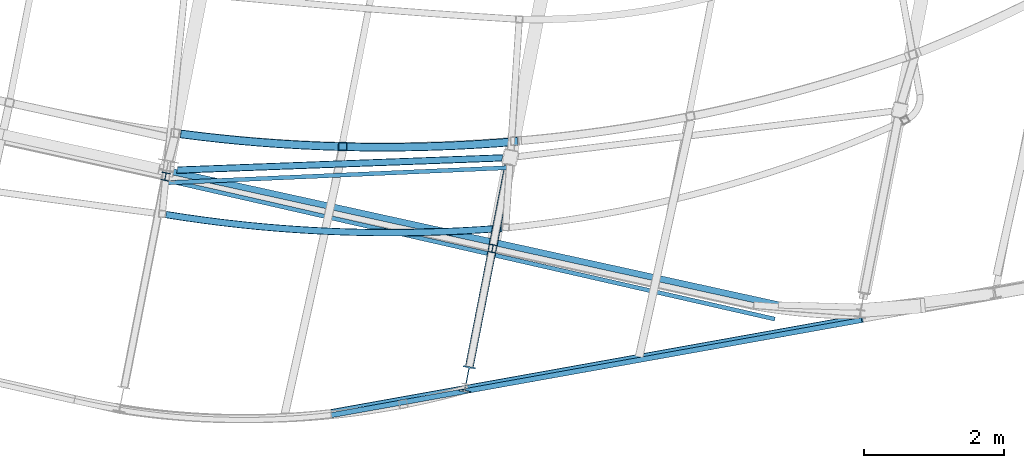
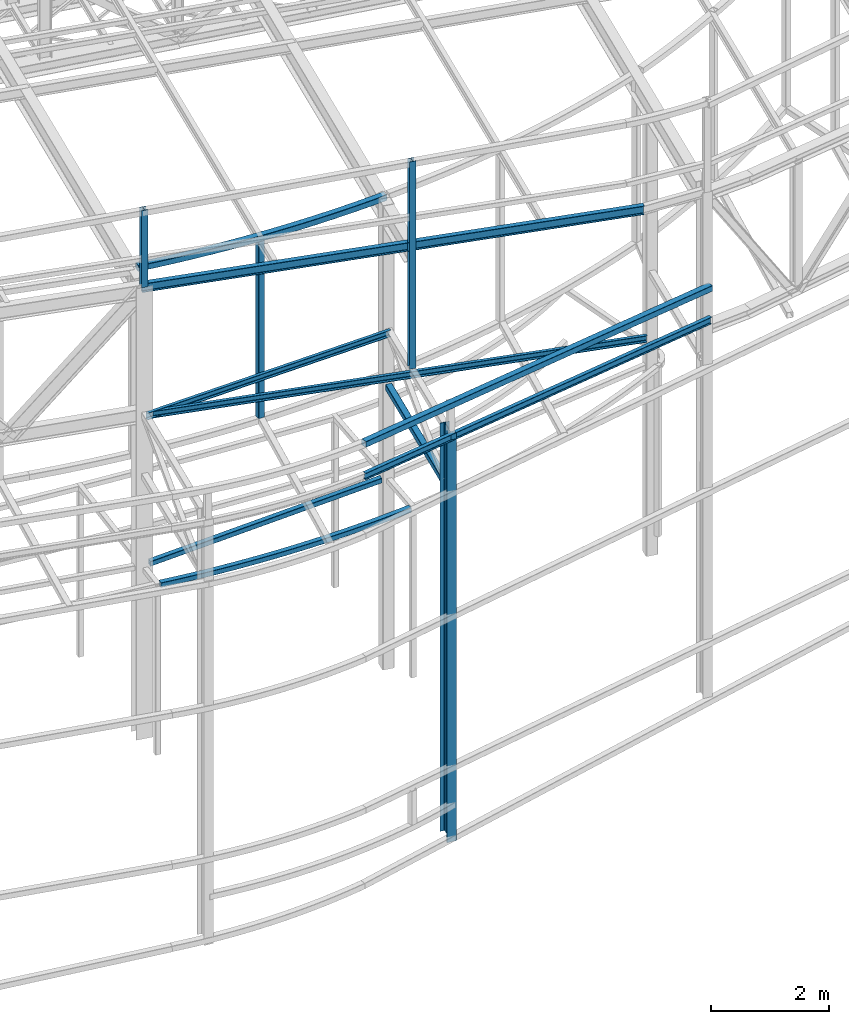
# One storey, part 51 of 215: 13 beams, 13 elements without a shape of their own.
"""IFC2X3 building model written with IfcOpenShell, lengths in millimetres."""

from ifc_helpers import new_model, entity, si_unit, frame, origin_with_axes, origin_2d_with_axis, place, context, subcontext, project, spatial, hollow_rectangle, i_section, u_section, extrude, clip, halfspace, material, type_object, element, aggregate, save


model = new_model("IFC2X3")

# Units and contexts
model_context = context("Model", 3, precision=1e-05, world=origin_with_axes())
body_context = subcontext(model_context, "Body", "Model", "MODEL_VIEW")
ifc_project = project(units=[si_unit("LENGTHUNIT", "METRE", prefix="MILLI"), si_unit("AREAUNIT", "SQUARE_METRE"), si_unit("VOLUMEUNIT", "CUBIC_METRE"), si_unit("MASSUNIT", "GRAM", prefix="KILO"), si_unit("TIMEUNIT", "SECOND"), si_unit("PLANEANGLEUNIT", "RADIAN"), si_unit("SOLIDANGLEUNIT", "STERADIAN"), si_unit("THERMODYNAMICTEMPERATUREUNIT", "DEGREE_CELSIUS"), si_unit("LUMINOUSINTENSITYUNIT", "LUMEN")], contexts=[model_context])

# Site, building, storey
site_placement = place(None, origin_with_axes())
site = spatial("IfcSite", under=ifc_project, at=site_placement, CompositionType="ELEMENT")
building_placement = place(site_placement, origin_with_axes())
building = spatial("IfcBuilding", under=site, at=building_placement, Name="Undefined", CompositionType="ELEMENT")
storey_placement = place(building_placement, origin_with_axes())
storey = spatial("IfcBuildingStorey", under=building, at=storey_placement, Name="Undefined", CompositionType="ELEMENT", Elevation=0.0)

# Assembly, beam
assembly_1_placement = place(storey_placement, origin_with_axes())
assembly_1 = element("IfcElementAssembly", 1, at=assembly_1_placement, inside=storey, Name="Steel Assembly", AssemblyPlace="NOTDEFINED", PredefinedType="RIGID_FRAME")
ifc_material = material(Name="STEEL/S275JR")
beam_type_1 = type_object("IfcBeamType", PredefinedType="NOTDEFINED")
beam_1_placement = place(assembly_1_placement, frame((74261.1152810842, 3775.93110748871, 6760.00000147687), z_axis=(-0.0375601719917873, 0.99929436778156, 0.0), x_axis=(0.99929436778156, 0.0375601719917896, 0.0)))
beam_1 = element("IfcBeam", 2, at=beam_1_placement, type_object=beam_type_1, material=ifc_material, Name="POUTRE", context=body_context, shape_type="Clipping", body=[
    clip(clip(extrude(hollow_rectangle(XDim=100.0, YDim=100.0, WallThickness=4.0, InnerFilletRadius=4.0, OuterFilletRadius=8.0, at=origin_2d_with_axis()), frame((4817.4486174556, 0.0, 0.0), z_axis=(-1.0, 0.0, 0.0), x_axis=(-6.93889390390723e-18, -1.0, -3.46944695195361e-18)), (0.0, 0.0, 1.0), 4692.2), halfspace(frame((4774.49299238823, -50.0, -81.9430866269604), z_axis=(0.973523614887649, 0.0, -0.228586463413922), x_axis=(-6.93889390390723e-18, -1.0, -3.46944695195361e-18)), False)), halfspace(frame((119.885956215003, -50.0, -123.641085699432), z_axis=(0.973523614887649, 0.0, -0.228586463413922), x_axis=(-6.93889390390723e-18, -1.0, -3.46944695195361e-18)), True)),
])
aggregate(assembly_1, [beam_1])

assembly_2_placement = place(storey_placement, origin_with_axes())
assembly_2 = element("IfcElementAssembly", 3, at=assembly_2_placement, inside=storey, Name="Steel Assembly", AssemblyPlace="NOTDEFINED", PredefinedType="RIGID_FRAME")
beam_2_placement = place(assembly_2_placement, frame((74250.9672434929, 3147.06143421459, 6760.00000147688), z_axis=(0.0406259980144075, 0.999174423354268, 0.0), x_axis=(0.999174423354268, -0.0406259980144044, 0.0)))
beam_2 = element("IfcBeam", 4, at=beam_2_placement, type_object=beam_type_1, material=ifc_material, Name="POUTRE", context=body_context, shape_type="SweptSolid", body=[
    entity("IfcRevolvedAreaSolid", entity("IfcRectangleHollowProfileDef", "AREA", None, entity("IfcAxis2Placement2D", entity("IfcCartesianPoint", [0.0, 0.0]), entity("IfcDirection", [1.0, 0.0])), 100.0, 100.0, 4.0, 4.0, 8.0), entity("IfcAxis2Placement3D", entity("IfcCartesianPoint", [4794.64242956755, 0.0, -9.42764216898869e-13]), entity("IfcDirection", [-0.99275375487674, 0.0, -0.120166476931518]), entity("IfcDirection", [-6.93889390390723e-18, -1.0, -3.46944695195361e-18])), entity("IfcAxis1Placement", entity("IfcCartesianPoint", [0.0, 19950.0, 0.0]), entity("IfcDirection", [-1.0, 0.0, 0.0])), 0.24091514552611),
])
aggregate(assembly_2, [beam_2])

assembly_3_placement = place(storey_placement, origin_with_axes())
assembly_3 = element("IfcElementAssembly", 5, at=assembly_3_placement, inside=storey, Name="Steel Assembly", AssemblyPlace="NOTDEFINED", PredefinedType="RIGID_FRAME")
beam_type_2 = type_object("IfcBeamType", PredefinedType="NOTDEFINED")
beam_3_placement = place(assembly_3_placement, frame((84192.2325806334, 1667.38669545206, 10334.7722522313), z_axis=(0.030333910010468, 0.00543797900187643, 0.999525028344889), x_axis=(-0.98384073926679, -0.176373700047828, 0.0308174900083568)))
beam_3 = element("IfcBeam", 6, at=beam_3_placement, type_object=beam_type_2, material=ifc_material, Name="LISSE", context=body_context, shape_type="SweptSolid", body=[
    extrude(hollow_rectangle(XDim=120.0, YDim=120.0, WallThickness=4.0, InnerFilletRadius=4.0, OuterFilletRadius=8.0, at=origin_2d_with_axis()), frame((7707.6528923593, -1.22814174666988e-13, -2.67412928341124e-14), z_axis=(-1.0, 0.0, 0.0), x_axis=(-6.93889390390723e-18, -1.0, -3.46944695195361e-18)), (0.0, 0.0, 1.0), 7707.7),
])
aggregate(assembly_3, [beam_3])

assembly_4_placement = place(storey_placement, origin_with_axes())
assembly_4 = element("IfcElementAssembly", 7, at=assembly_4_placement, inside=storey, Name="Steel Assembly", AssemblyPlace="NOTDEFINED", PredefinedType="RIGID_FRAME")
beam_type_3 = type_object("IfcBeamType", PredefinedType="NOTDEFINED")
beam_4_placement = place(assembly_4_placement, frame((76773.3596225124, 4118.8705925803, 12545.1918488678), z_axis=(-0.00211529999947707, -0.999997762750453, 0.0), x_axis=(0.0, 0.0, -1.0)))
beam_4 = element("IfcBeam", 8, at=beam_4_placement, type_object=beam_type_3, material=ifc_material, Name="LISSE", context=body_context, shape_type="SweptSolid", body=[
    extrude(hollow_rectangle(XDim=120.0, YDim=120.0, WallThickness=5.0, InnerFilletRadius=5.0, OuterFilletRadius=10.0, at=origin_2d_with_axis()), frame((3779.1910443004, -1.45519152533754e-11, 0.0), z_axis=(-1.0, 0.0, 0.0), x_axis=(-6.93889390390723e-18, -1.0, -3.46944695195361e-18)), (0.0, 0.0, 1.0), 3779.2),
])
aggregate(assembly_4, [beam_4])

assembly_5_placement = place(storey_placement, origin_with_axes())
assembly_5 = element("IfcElementAssembly", 9, at=assembly_5_placement, inside=storey, Name="Steel Assembly", AssemblyPlace="NOTDEFINED", PredefinedType="RIGID_FRAME")
beam_5_placement = place(assembly_5_placement, frame((79267.1867346252, 4191.7690236405, 12410.541358688), z_axis=(-0.0310311480063228, 0.000686511000139884, -0.999518182203834), x_axis=(-0.999273695664124, 0.0221060559925697, 0.0310387409895674)))
beam_5 = element("IfcBeam", 10, at=beam_5_placement, type_object=beam_type_3, material=ifc_material, Name="LISSE", context=body_context, shape_type="SweptSolid", body=[
    entity("IfcRevolvedAreaSolid", entity("IfcRectangleHollowProfileDef", "AREA", None, entity("IfcAxis2Placement2D", entity("IfcCartesianPoint", [0.0, 0.0]), entity("IfcDirection", [1.0, 0.0])), 120.0, 120.0, 5.0, 5.0, 10.0), entity("IfcAxis2Placement3D", entity("IfcCartesianPoint", [4808.92307548659, -9.31427089451216e-13, 1.66843035064264e-14]), entity("IfcDirection", [-0.994042139631075, -0.108996443234057, -3.43653205685092e-18]), entity("IfcDirection", [0.108996443234057, -0.994042139631075, 4.89825829785122e-19])), entity("IfcAxis1Placement", entity("IfcCartesianPoint", [-22060.0, 0.0, 0.0]), entity("IfcDirection", [-6.93889390390723e-18, -1.0, -3.46944695195361e-18])), 0.218426844555447),
])
aggregate(assembly_5, [beam_5])

assembly_6_placement = place(storey_placement, origin_with_axes())
assembly_6 = element("IfcElementAssembly", 11, at=assembly_6_placement, inside=storey, Name="Steel Assembly", AssemblyPlace="NOTDEFINED", PredefinedType="RIGID_FRAME")
beam_6_placement = place(assembly_6_placement, frame((79143.2731267829, 3852.2721506294, 8710.00002272178), z_axis=(0.0, 0.0, 1.0), x_axis=(-0.191859508000518, -0.981422401002646, -1.00000033853845e-09)))
beam_6 = element("IfcBeam", 12, at=beam_6_placement, type_object=beam_type_3, material=ifc_material, Name="POUTRE", context=body_context, shape_type="SweptSolid", body=[
    extrude(hollow_rectangle(XDim=120.0, YDim=120.0, WallThickness=5.0, InnerFilletRadius=5.0, OuterFilletRadius=10.0, at=origin_2d_with_axis()), frame((2932.26845998588, 5.62583432590047e-16, -6.06378905225262e-22), z_axis=(-1.0, 0.0, 0.0), x_axis=(-6.93889390390723e-18, -1.0, -3.46944695195361e-18)), (0.0, 0.0, 1.0), 2932.3),
])
aggregate(assembly_6, [beam_6])

assembly_7_placement = place(storey_placement, origin_with_axes())
assembly_7 = element("IfcElementAssembly", 13, at=assembly_7_placement, inside=storey, Name="Steel Assembly", AssemblyPlace="NOTDEFINED", PredefinedType="RIGID_FRAME")
beam_type_4 = type_object("IfcBeamType", Name="UPN140", PredefinedType="NOTDEFINED")
beam_7_placement = place(assembly_7_placement, frame((82939.485591898, 1655.68782087957, 9717.96646806902), z_axis=(-0.0268944750036359, 0.00613499200083085, -0.999619452135376), x_axis=(-0.974584372423982, 0.222315879096716, 0.0275853390120007)))
beam_7 = element("IfcBeam", 14, at=beam_7_placement, type_object=beam_type_4, material=ifc_material, ObjectType="UPN140", context=body_context, shape_type="SweptSolid", body=[
    extrude(u_section(Depth=140.0, FlangeWidth=60.0, WebThickness=7.0, FlangeThickness=10.0, FilletRadius=10.0, EdgeRadius=5.0, FlangeSlope=0.0798299857122373, at=origin_2d_with_axis()), frame((8783.7502311137, 3.44692992864887e-12, 3.04747554660593e-14), z_axis=(-1.0, 0.0, 0.0), x_axis=(-6.93889390390723e-18, -1.0, -3.46944695195361e-18)), (0.0, 0.0, 1.0), 8783.8),
])
aggregate(assembly_7, [beam_7])

assembly_8_placement = place(storey_placement, origin_with_axes())
assembly_8 = element("IfcElementAssembly", 15, at=assembly_8_placement, inside=storey, Name="Steel Assembly", AssemblyPlace="NOTDEFINED", PredefinedType="RIGID_FRAME")
beam_8_placement = place(assembly_8_placement, frame((79149.5642694541, 3816.73288514796, 9850.00376637178), z_axis=(-0.0238106859918893, -0.00105414299964089, -0.999715929659587), x_axis=(-0.998737583884963, -0.044217400994907, 0.0238340089972549)))
beam_8 = element("IfcBeam", 16, at=beam_8_placement, type_object=beam_type_4, material=ifc_material, ObjectType="UPN140", context=body_context, shape_type="SweptSolid", body=[
    extrude(u_section(Depth=140.0, FlangeWidth=60.0, WebThickness=7.0, FlangeThickness=10.0, FilletRadius=10.0, EdgeRadius=5.0, FlangeSlope=0.0798299857122373, at=origin_2d_with_axis()), frame((4901.31854594592, -2.88501916874359e-13, 3.62097394240193e-12), z_axis=(-1.0, 0.0, 0.0), x_axis=(-6.93889390390723e-18, -1.0, -3.46944695195361e-18)), (0.0, 0.0, 1.0), 4901.3),
])
aggregate(assembly_8, [beam_8])

assembly_9_placement = place(storey_placement, origin_with_axes())
assembly_9 = element("IfcElementAssembly", 17, at=assembly_9_placement, inside=storey, Name="Steel Assembly", AssemblyPlace="NOTDEFINED", PredefinedType="RIGID_FRAME")
beam_type_5 = type_object("IfcBeamType", Name="IPE180", PredefinedType="NOTDEFINED")
beam_9_placement = place(assembly_9_placement, frame((82992.4866050299, 1858.39207406567, 12256.4650243686), z_axis=(0.0302564720050506, -0.00664840000111122, 0.999520057167055), x_axis=(-0.976230219438185, 0.214510847096284, 0.0309783010139048)))
beam_9 = element("IfcBeam", 18, at=beam_9_placement, type_object=beam_type_5, material=ifc_material, Name="POUTRE", ObjectType="IPE180", context=body_context, shape_type="SweptSolid", body=[
    extrude(i_section(OverallWidth=91.0, OverallDepth=180.0, WebThickness=5.300000191, FlangeThickness=8.0, FilletRadius=9.0, at=origin_2d_with_axis()), frame((8946.73682634362, -1.51116123446438e-13, 3.1040228812089e-14), z_axis=(-1.0, 0.0, 0.0), x_axis=(-6.93889390390723e-18, -1.0, -3.46944695195361e-18)), (0.0, 0.0, 1.0), 8946.7),
])
aggregate(assembly_9, [beam_9])

assembly_10_placement = place(storey_placement, origin_with_axes())
assembly_10 = element("IfcElementAssembly", 19, at=assembly_10_placement, inside=storey, Name="Steel Assembly", AssemblyPlace="NOTDEFINED", PredefinedType="RIGID_FRAME")
beam_type_6 = type_object("IfcBeamType", Name="HEA120", PredefinedType="NOTDEFINED")
beam_10_placement = place(assembly_10_placement, frame((78910.6292688949, 2662.22415404674, 14219.9969962712), z_axis=(0.191859470081235, 0.981422408415534, 0.0), x_axis=(0.0, 0.0, -1.0)))
beam_10 = element("IfcBeam", 20, at=beam_10_placement, type_object=beam_type_6, material=ifc_material, ObjectType="HEA120", context=body_context, shape_type="SweptSolid", body=[
    extrude(i_section(OverallWidth=120.0, OverallDepth=114.0, WebThickness=5.0, FlangeThickness=8.0, FilletRadius=12.0, at=origin_2d_with_axis()), frame((4300.01311252335, 1.45519152283669e-11, 0.0), z_axis=(-1.0, 0.0, 0.0), x_axis=(-6.93889390390723e-18, -1.0, -3.46944695195361e-18)), (0.0, 0.0, 1.0), 4300.0),
])
aggregate(assembly_10, [beam_10])

assembly_11_placement = place(storey_placement, origin_with_axes())
assembly_11 = element("IfcElementAssembly", 21, at=assembly_11_placement, inside=storey, Name="Steel Assembly", AssemblyPlace="NOTDEFINED", PredefinedType="RIGID_FRAME")
beam_11_placement = place(assembly_11_placement, frame((74244.1095571485, 3689.07435513342, 14219.9969942744), z_axis=(0.191859470081235, 0.981422408415534, 0.0), x_axis=(0.0, 0.0, -1.0)))
beam_11 = element("IfcBeam", 22, at=beam_11_placement, type_object=beam_type_6, material=ifc_material, ObjectType="HEA120", context=body_context, shape_type="SweptSolid", body=[
    extrude(i_section(OverallWidth=120.0, OverallDepth=114.0, WebThickness=5.0, FlangeThickness=8.0, FilletRadius=12.0, at=origin_2d_with_axis()), frame((1598.43144151106, 0.0, 0.0), z_axis=(-1.0, 0.0, 0.0), x_axis=(-6.93889390390723e-18, -1.0, -3.46944695195361e-18)), (0.0, 0.0, 1.0), 1598.4),
])
aggregate(assembly_11, [beam_11])

assembly_12_placement = place(storey_placement, origin_with_axes())
assembly_12 = element("IfcElementAssembly", 23, at=assembly_12_placement, inside=storey, Name="Steel Assembly", AssemblyPlace="NOTDEFINED", PredefinedType="RIGID_FRAME")
beam_type_7 = type_object("IfcBeamType", Name="IPE360", PredefinedType="NOTDEFINED")
beam_12_placement = place(assembly_12_placement, frame((78546.1550974716, 797.822117158516, 9919.98388578036), z_axis=(0.191859470081235, 0.981422408415534, 0.0), x_axis=(0.0, 0.0, -1.0)))
beam_12 = element("IfcBeam", 24, at=beam_12_placement, type_object=beam_type_7, material=ifc_material, Name="MONTANT", ObjectType="IPE360", context=body_context, shape_type="Clipping", body=[
    clip(extrude(i_section(OverallWidth=170.0, OverallDepth=360.0, WebThickness=8.0, FlangeThickness=12.69999981, FilletRadius=18.0, at=origin_2d_with_axis()), frame((8472.90549882885, 0.0, 0.0), z_axis=(-1.0, 0.0, 0.0), x_axis=(-6.93889390390723e-18, -1.0, -3.46944695195361e-18)), (0.0, 0.0, 1.0), 8472.9), halfspace(frame((8471.40475381312, 34.9625290201366, -220.155723962436), z_axis=(-0.999000449365305, 0.04166508940975, -0.0161901974168687), x_axis=(-6.46126864261808e-10, 0.362195693917388, 0.93210207558384)), True)),
])
aggregate(assembly_12, [beam_12])

assembly_13_placement = place(storey_placement, origin_with_axes())
assembly_13 = element("IfcElementAssembly", 25, at=assembly_13_placement, inside=storey, Name="Steel Assembly", AssemblyPlace="NOTDEFINED", PredefinedType="RIGID_FRAME")
beam_type_8 = type_object("IfcBeamType", Name="IPE140", PredefinedType="NOTDEFINED")
beam_13_placement = place(assembly_13_placement, frame((76607.1936489951, 283.874341071334, 9910.21639576506), z_axis=(-0.029519147010351, -0.00530347900185983, -0.999550145350526), x_axis=(0.983867126535779, 0.176368847916783, -0.0299917789858489)))
beam_13 = element("IfcBeam", 26, at=beam_13_placement, type_object=beam_type_8, material=ifc_material, Name="LISSE", ObjectType="IPE140", context=body_context, shape_type="SweptSolid", body=[
    extrude(i_section(OverallWidth=73.0, OverallDepth=140.0, WebThickness=4.699999809, FlangeThickness=6.900000095, FilletRadius=7.0, at=origin_2d_with_axis()), frame((7692.87648931607, 1.41896654787936e-13, 1.79229937665824e-12), z_axis=(-1.0, 0.0, 0.0), x_axis=(-6.93889390390723e-18, -1.0, -3.46944695195361e-18)), (0.0, 0.0, 1.0), 7692.9),
])
aggregate(assembly_13, [beam_13])

save(model, "model.ifc")
